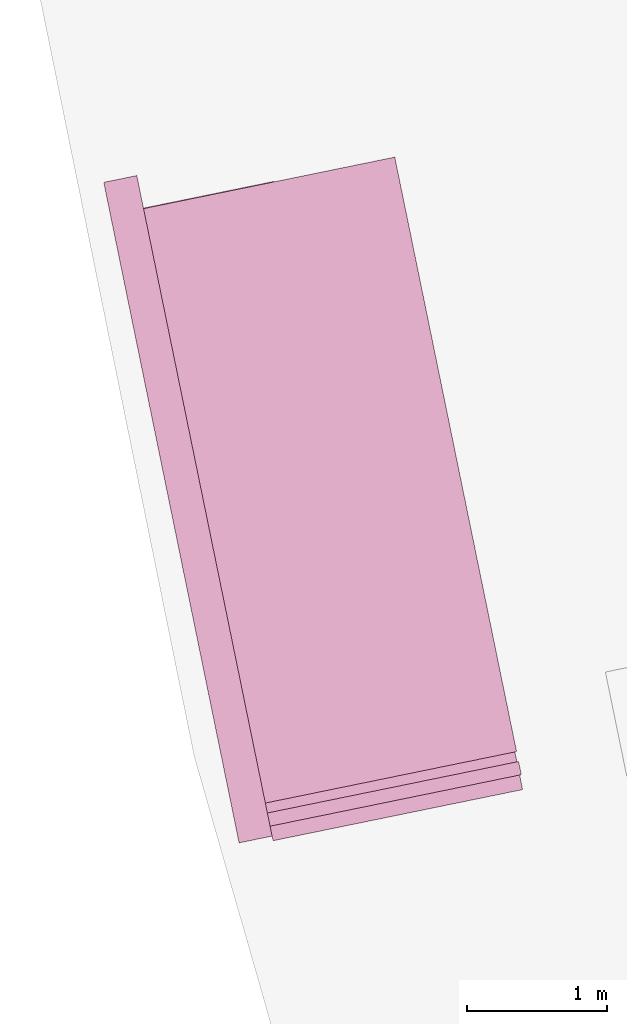
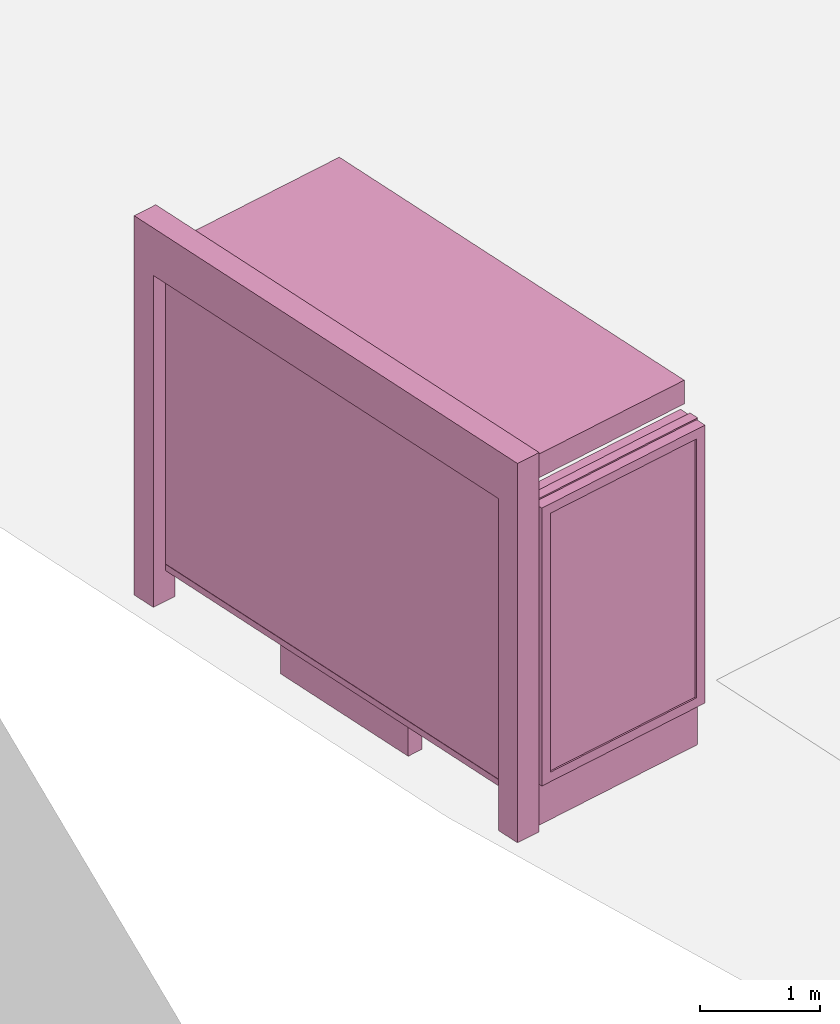
# One storey, part 26 of 200: 1 furnishing.
"""IFC4 building model written with IfcOpenShell, lengths in metres."""

from ifc_helpers import new_model, si_unit, origin_with_axes, place, context, subcontext, project, spatial, triangles, material, element, save


model = new_model("IFC4")

# Units and contexts
model_context = context("Model", 3, precision=1e-05, world=origin_with_axes())
body_context = subcontext(model_context, "Body", "Model", "MODEL_VIEW")
ifc_project = project(units=[si_unit("VOLUMEUNIT", "CUBIC_METRE"), si_unit("LENGTHUNIT", "METRE"), si_unit("AREAUNIT", "SQUARE_METRE")], contexts=[model_context])

# Site, building, storey
site_placement = place(None, origin_with_axes())
site = spatial("IfcSite", under=ifc_project, at=site_placement)
building_placement = place(site_placement, origin_with_axes())
building = spatial("IfcBuilding", under=site, at=building_placement, Name="Building")
storey_placement = place(building_placement, origin_with_axes())
storey = spatial("IfcBuildingStorey", under=building, at=storey_placement, Name="Ground")

# Furnishing
ifc_material = material(Name="busStop")
furnishing_placement = place(storey_placement, origin_with_axes())
element("IfcFurnishingElement", 1, at=furnishing_placement, inside=storey, material=ifc_material, Name="cw_instances_busStop_34", context=body_context, shape_type="Tessellation", body=[
    triangles([(176.34061056625512, -426.87686979367874, 3.3823837170154), (173.43771713825552, -423.0430857488788, 3.3823837170154), (174.30847300968287, -427.2932084161161, 3.3823837170154), (175.46985486398805, -422.62674691136294, 3.3823837170154), (176.34061066070228, -426.87686977432855, 3.623406387340317), (173.43771723270268, -423.0430857295286, 3.623406387340317), (175.4698549584352, -422.6267468920128, 3.623406387340317), (174.30847310413003, -427.293208396766, 3.623406387340317), (176.34061056625512, -426.87686979367874, 3.3823837170154), (175.4698549584352, -422.6267468920128, 3.623406387340317), (175.46985486398805, -422.62674691136294, 3.3823837170154), (176.34061066070228, -426.87686977432855, 3.623406387340317), (175.46985486398805, -422.62674691136294, 3.3823837170154), (173.43771723270268, -423.0430857295286, 3.623406387340317), (173.43771713825552, -423.0430857488788, 3.3823837170154), (175.4698549584352, -422.6267468920128, 3.623406387340317), (173.43771713825552, -423.0430857488788, 3.3823837170154), (174.30847310413003, -427.293208396766, 3.623406387340317), (174.30847300968287, -427.2932084161161, 3.3823837170154), (173.43771723270268, -423.0430857295286, 3.623406387340317), (174.30847300968287, -427.2932084161161, 3.3823837170154), (176.34061066070228, -426.87686977432855, 3.623406387340317), (176.34061056625512, -426.87686979367874, 3.3823837170154), (174.30847310413003, -427.293208396766, 3.623406387340317), (174.5445913562034, -427.2448329499997, 3.864428655961051), (174.35684887746848, -427.5293264015106, 3.864428655961051), (174.3084734661775, -427.2932083225904, 3.864428655961051), (174.59296676749437, -427.48095102891995, 3.864428655961051), (174.5445913562034, -427.2448329499997, 3.623406387340317), (174.59296676749437, -427.48095102891995, 3.864428655961051), (174.5445913562034, -427.2448329499997, 3.864428655961051), (174.59296676749437, -427.48095102891995, 3.623406387340317), (173.62546032004596, -422.75859236655236, 3.623406387340317), (173.38934224112572, -422.80696777784334, 3.864428655961051), (173.38934224112572, -422.80696777784334, 3.623406387340317), (173.62546032004596, -422.75859236655236, 3.864428655961051), (173.43771761049138, -423.04308565212807, 3.623406387340317), (173.38934224112572, -422.80696777784334, 3.864428655961051), (173.43771761049138, -423.04308565212807, 3.864428655961051), (173.38934224112572, -422.80696777784334, 3.623406387340317), (174.35684870431535, -427.5293264369859, 3.623406387340317), (174.59296676749437, -427.48095102891995, 3.864428655961051), (174.59296676749437, -427.48095102891995, 3.623406387340317), (174.35684887746848, -427.5293264015106, 3.864428655961051), (173.67383550051727, -422.99471027953734, 3.864428655961051), (173.43771761049138, -423.04308565212807, 3.864428655961051), (173.67383550051727, -422.99471027953734, 3.623406387340317), (173.67383550051727, -422.99471027953734, 3.864428655961051), (174.35684870431535, -427.5293264369859, 3.623406387340317), (174.3084734661775, -427.2932083225904, 3.864428655961051), (174.35684887746848, -427.5293264015106, 3.864428655961051), (174.3084734661775, -427.2932083225904, 3.623406387340317), (173.62546032004596, -422.75859236655236, 3.864428655961051), (173.38934224112572, -422.80696777784334, 3.864428655961051), (173.62546032004596, -422.75859236655236, 3.623406387340317), (173.62546032004596, -422.75859236655236, 3.864428655961051), (174.35684785429083, -427.52932661113726, 9.480218712634252e-07), (174.59296564986954, -427.4809512578967, 8.998173693347766e-07), (174.30847244299986, -427.293208532217, 9.480218712634252e-07), (174.35684785429083, -427.52932661113726, 9.480218712634252e-07), (174.3084734661775, -427.2932083225904, 3.623406387340317), (174.54459041173172, -427.24483314350124, 8.998173693347766e-07), (174.5445913562034, -427.2448329499997, 3.623406387340317), (174.30847244299986, -427.293208532217, 9.480218712634252e-07), (174.59296564986954, -427.4809512578967, 8.998173693347766e-07), (174.54459041173172, -427.24483314350124, 8.998173693347766e-07), (173.62545949305732, -422.7585940941677, 8.998173693347766e-07), (173.38934121794804, -422.80696798747, 9.480218712634252e-07), (173.673834865648, -422.9947119841936, 8.998173693347766e-07), (173.62545949305732, -422.7585940941677, 8.998173693347766e-07), (173.67383550051727, -422.99471027953734, 3.623406387340317), (173.43771689691613, -423.0430873729094, 9.480218712634252e-07), (173.43771761049138, -423.04308565212807, 3.623406387340317), (173.673834865648, -422.9947119841936, 8.998173693347766e-07), (173.38934121794804, -422.80696798747, 9.480218712634252e-07), (173.43771689691613, -423.0430873729094, 9.480218712634252e-07), (174.60586565573203, -422.8040135152526, 0.34596862720110877), (173.58096167477387, -423.0139938430587, 3.3823837170154), (173.58096082474935, -423.01399401721005, 0.34596880395094914), (174.6058664270506, -422.8040133572264, 3.3823837170154), (173.5841858467937, -423.0297351962361, 0.34596880395094914), (174.60909144909493, -422.81975453625245, 3.3823837170154), (174.6090906777764, -422.8197546942787, 0.34596862720110877), (173.58418669681822, -423.0297350220847, 3.3823837170154), (174.6090906777764, -422.8197546942787, 0.34596862720110877), (174.6058664270506, -422.8040133572264, 3.3823837170154), (174.60586565573203, -422.8040135152526, 0.34596862720110877), (174.60909144909493, -422.81975453625245, 3.3823837170154), (173.58499212246122, -423.03367058937505, 0.31383250146818464), (174.60505937154127, -422.8000783206831, 0.3138323086501769), (173.58015458778215, -423.01005881296544, 0.31383250146818464), (174.6098969062203, -422.8236900970927, 0.3138323086501769), (173.58499212246122, -423.03367058937505, 0.378105122501881), (174.60505938728247, -422.80007831745803, 0.3781049296838733), (174.6098969219615, -422.8236900938677, 0.3781049296838733), (173.58015458778215, -423.01005881296544, 0.378105122501881), (173.58499212246122, -423.03367058937505, 0.31383250146818464), (174.6098969219615, -422.8236900938677, 0.3781049296838733), (174.6098969062203, -422.8236900970927, 0.3138323086501769), (173.58499212246122, -423.03367058937505, 0.378105122501881), (174.60505937154127, -422.8000783206831, 0.3138323086501769), (173.58015458778215, -423.01005881296544, 0.378105122501881), (173.58015458778215, -423.01005881296544, 0.31383250146818464), (174.60505938728247, -422.80007831745803, 0.3781049296838733), (174.60505938728247, -422.80007831745803, 0.3781049296838733), (174.6098969062203, -422.8236900970927, 0.3138323086501769), (174.6098969219615, -422.8236900938677, 0.3781049296838733), (174.60505937154127, -422.8000783206831, 0.3138323086501769), (174.63082386660048, -422.81559415936135, 0.3781049296838733), (174.58413291365076, -422.8081759104721, 0.3781049296838733), (174.62748435293403, -422.79929415217987, 0.3781049296838733), (174.5874724273172, -422.8244759176535, 0.3781049296838733), (174.63082361474136, -422.8155942109617, 1.446135057859462e-07), (174.62748435293403, -422.79929415217987, 0.3781049296838733), (174.6274841010749, -422.7992942037803, 1.446135057859462e-07), (174.63082386660048, -422.81559415936135, 0.3781049296838733), (174.6274841010749, -422.7992942037803, 1.446135057859462e-07), (174.58413291365076, -422.8081759104721, 0.3781049296838733), (174.5841328034624, -422.8081759330472, 1.606816730954958e-07), (174.62748435293403, -422.79929415217987, 0.3781049296838733), (174.5841328034624, -422.8081759330472, 1.606816730954958e-07), (174.5874724273172, -422.8244759176535, 0.3781049296838733), (174.58747231712886, -422.8244759402287, 1.606816730954958e-07), (174.58413291365076, -422.8081759104721, 0.3781049296838733), (174.58747231712886, -422.8244759402287, 1.606816730954958e-07), (174.63082386660048, -422.81559415936135, 0.3781049296838733), (174.63082361474136, -422.8155942109617, 1.446135057859462e-07), (174.5874724273172, -422.8244759176535, 0.3781049296838733), (174.34685790137442, -425.9517340658489, 1.1247720651681516), (173.874052638298, -424.4084083204333, 1.1247721615771553), (174.0243558466721, -424.3776144923762, 1.1247720651681516), (174.19655488189463, -425.9825278552057, 1.1247721615771553), (174.02435565777776, -424.3776145310765, 4.98113186596037e-07), (174.34685790137442, -425.9517340658489, 0.9640904563453251), (174.0243558466721, -424.3776144923762, 0.9640904563453251), (174.34685757080933, -425.9517341335744, 4.98113186596037e-07), (173.8740522605093, -424.4084083978339, 5.302495212151362e-07), (174.0243558466721, -424.3776144923762, 0.9640904563453251), (173.874052638298, -424.4084083204333, 0.9640905527543289), (174.02435565777776, -424.3776145310765, 4.98113186596037e-07), (174.19655450410596, -425.98252793260633, 5.302495212151362e-07), (173.874052638298, -424.4084083204333, 0.9640905527543289), (174.19655488189463, -425.9825278552057, 0.9640905527543289), (173.8740522605093, -424.4084083978339, 5.302495212151362e-07), (174.34685757080933, -425.9517341335744, 4.98113186596037e-07), (174.19655488189463, -425.9825278552057, 0.9640905527543289), (174.34685790137442, -425.9517340658489, 0.9640904563453251), (174.19655450410596, -425.98252793260633, 5.302495212151362e-07), (174.65400357439609, -424.248613494501, 1.1247719687591475), (174.97650570780436, -425.82273305184856, 0.9640903599363211), (174.97650573928678, -425.82273304539854, 1.1247719687591475), (174.6540035586549, -424.24861349772607, 0.9640903599363211), (173.874052638298, -424.4084083204333, 1.1247721615771553), (174.0243558466721, -424.3776144923762, 1.1247720651681516), (174.19655488189463, -425.9825278552057, 1.1247721615771553), (173.874052638298, -424.4084083204333, 1.1247721615771553), (174.34685790137442, -425.9517340658489, 1.1247720651681516), (174.19655488189463, -425.9825278552057, 1.1247721615771553), (174.97650573928678, -425.82273304539854, 1.1247719687591475), (174.65400357439609, -424.248613494501, 1.1247719687591475), (174.97650570780436, -425.82273305184856, 0.9640903599363211), (174.97650573928678, -425.82273304539854, 1.1247719687591475), (174.65400357439609, -424.248613494501, 1.1247719687591475), (174.6540035586549, -424.24861349772607, 0.9640903599363211), (174.48756851526701, -427.3990797429234, 0.34596880395094914), (173.56459436062397, -422.89407683812993, 3.5028950521778586), (173.56459343189348, -422.89407702840646, 0.34596880395094914), (174.48756917639722, -427.39907960747234, 3.5028950521778586), (173.54885223712625, -422.89730205367584, 0.34596880395094914), (174.47182799737118, -427.4023046295167, 3.5028950521778586), (174.471827336241, -427.40230476496777, 0.34596880395094914), (173.54885318159793, -422.8973018601743, 3.5028950521778586), (174.6909800972454, -427.4790123437563, 0.5809565598614106), (176.2860976666566, -427.1522077685599, 3.219113622848009), (176.28609709997357, -427.1522078846608, 0.5809562706343991), (174.6909806954108, -427.4790122212054, 3.219113622848009), (174.5997579506864, -427.51410367439865, 0.48454753993594585), (176.28932212201792, -427.1679490636868, 0.5809562706343991), (176.38376950255147, -427.1486004268342, 0.48454721857259964), (174.69420511928973, -427.4947535227824, 0.5809565598614106), (176.28932268870093, -427.1679489475859, 3.219113622848009), (176.38377004619858, -427.1485987572693, 3.3155225302963025), (174.69420571745513, -427.4947534002314, 3.219113622848009), (174.5997585960754, -427.5141035421726, 3.3155225302963025), (174.69420511928973, -427.4947535227824, 0.5809565598614106), (176.28609709997357, -427.1522078846608, 0.5809562706343991), (176.28932212201792, -427.1679490636868, 0.5809562706343991), (174.6909800972454, -427.4790123437563, 0.5809565598614106), (176.28932212201792, -427.1679490636868, 0.5809562706343991), (176.2860976666566, -427.1522077685599, 3.219113622848009), (176.28932268870093, -427.1679489475859, 3.219113622848009), (176.28609709997357, -427.1522078846608, 0.5809562706343991), (176.28932268870093, -427.1679489475859, 3.219113622848009), (174.6909806954108, -427.4790122212054, 3.219113622848009), (174.69420571745513, -427.4947534002314, 3.219113622848009), (176.2860976666566, -427.1522077685599, 3.219113622848009), (174.69420571745513, -427.4947534002314, 3.219113622848009), (174.6909800972454, -427.4790123437563, 0.5809565598614106), (174.69420511928973, -427.4947535227824, 0.5809565598614106), (174.6909806954108, -427.4790122212054, 3.219113622848009), (176.32181022216824, -426.84617580664496, 3.3155225302963025), (174.5997585960754, -427.5141035421726, 3.3155225302963025), (174.53779905538656, -427.21168053349777, 3.3155225302963025), (176.38377004619858, -427.1485987572693, 3.3155225302963025), (176.32180937214372, -426.8461759807963, 0.48454721857259964), (176.38377004619858, -427.1485987572693, 3.3155225302963025), (176.32181022216824, -426.84617580664496, 3.3155225302963025), (176.38376950255147, -427.1486004268342, 0.48454721857259964), (174.5997579506864, -427.51410367439865, 0.48454753993594585), (174.53779905538656, -427.21168053349777, 3.3155225302963025), (174.5997585960754, -427.5141035421726, 3.3155225302963025), (174.5377982998092, -427.211680688299, 0.48454753993594585), (174.63547045897448, -427.20807172215876, 0.5809565598614106), (176.23058788671494, -426.88126717598755, 3.219113622848009), (174.63547124603423, -427.2080715609075, 3.219113622848009), (176.23058732003193, -426.88126729208847, 0.5809562706343991), (174.5377982998092, -427.211680688299, 0.48454753993594585), (176.22736229798755, -426.86552611306246, 0.5809562706343991), (174.63224543693013, -427.19233054313275, 0.5809565598614106), (176.32180937214372, -426.8461759807963, 0.48454721857259964), (176.22736286467057, -426.86552599696154, 3.219113622848009), (176.32181022216824, -426.84617580664496, 3.3155225302963025), (174.63224622398985, -427.1923303818815, 3.219113622848009), (174.53779905538656, -427.21168053349777, 3.3155225302963025), (174.63224543693013, -427.19233054313275, 0.5809565598614106), (176.23058732003193, -426.88126729208847, 0.5809562706343991), (174.63547045897448, -427.20807172215876, 0.5809565598614106), (176.22736229798755, -426.86552611306246, 0.5809562706343991), (176.22736229798755, -426.86552611306246, 0.5809562706343991), (176.23058788671494, -426.88126717598755, 3.219113622848009), (176.23058732003193, -426.88126729208847, 0.5809562706343991), (176.22736286467057, -426.86552599696154, 3.219113622848009), (176.22736286467057, -426.86552599696154, 3.219113622848009), (174.63547124603423, -427.2080715609075, 3.219113622848009), (176.23058788671494, -426.88126717598755, 3.219113622848009), (174.63224622398985, -427.1923303818815, 3.219113622848009), (174.63224622398985, -427.1923303818815, 3.219113622848009), (174.63547045897448, -427.20807172215876, 0.5809565598614106), (174.63547124603423, -427.2080715609075, 3.219113622848009), (174.63224543693013, -427.19233054313275, 0.5809565598614106), (176.374472992956, -427.04215068590906, 3.328512133158346), (174.55910361792715, -427.31566852978233, 3.328512133158346), (176.35512316706723, -426.9477051071664, 3.328512133158346), (174.5784537501933, -427.4101156039385, 3.328512133158346), (176.3744726769035, -427.04215250566796, 0.0), (176.35512316706723, -426.9477051071664, 3.328512133158346), (176.35512250593706, -426.9477052426175, 0.0), (176.374472992956, -427.04215068590906, 3.328512133158346), (176.35512250593706, -426.9477052426175, 0.0), (174.55910361792715, -427.31566852978233, 3.328512133158346), (174.55910287809098, -427.31566868135855, 5.141813539055866e-07), (176.35512316706723, -426.9477051071664, 3.328512133158346), (174.55910287809098, -427.31566868135855, 5.141813539055866e-07), (174.5784537501933, -427.4101156039385, 3.328512133158346), (174.57845301035712, -427.4101157555147, 5.141813539055866e-07), (174.55910361792715, -427.31566852978233, 3.328512133158346), (174.57845301035712, -427.4101157555147, 5.141813539055866e-07), (176.374472992956, -427.04215068590906, 3.328512133158346), (176.3744726769035, -427.04215250566796, 0.0), (174.5784537501933, -427.4101156039385, 3.328512133158346), (174.49150381395884, -427.39827348660606, 0.31383250146818464), (173.56488588401888, -422.99557618277385, 0.31383250146818464), (174.46789194310202, -427.4031110406353, 0.31383250146818464), (173.58849764468732, -422.9907386513198, 0.31383250146818464), (174.49150381395884, -427.39827348660606, 0.378105122501881), (173.56488588401888, -422.99557618277385, 0.378105122501881), (173.58849764468732, -422.9907386513198, 0.378105122501881), (174.46789194310202, -427.4031110406353, 0.378105122501881), (174.49150381395884, -427.39827348660606, 0.31383250146818464), (173.58849764468732, -422.9907386513198, 0.378105122501881), (173.58849764468732, -422.9907386513198, 0.31383250146818464), (174.49150381395884, -427.39827348660606, 0.378105122501881), (173.56488588401888, -422.99557618277385, 0.31383250146818464), (174.46789194310202, -427.4031110406353, 0.378105122501881), (174.46789194310202, -427.4031110406353, 0.31383250146818464), (173.56488588401888, -422.99557618277385, 0.378105122501881), (174.16519614520405, -425.82493276341637, 1.5289466322217304), (173.9071947815587, -424.5656370308466, 2.8143998402358568), (174.16519652299274, -425.82493268601576, 2.8143998402358568), (173.90719440377003, -424.5656371082472, 1.5289466322217304), (174.17197755733739, -425.7907395212252, 1.5610831275225028), (173.92687628547841, -424.5944086024317, 2.7822635377530918), (173.9268757345366, -424.5944087153076, 1.5610831275225028), (174.17197774623173, -425.7907394825249, 2.7822635377530918), (174.16519614520405, -425.82493276341637, 1.5289466322217304), (173.93616704869316, -424.5597012492873, 1.5289466322217304), (173.90719440377003, -424.5656371082472, 1.5289466322217304), (174.19416860123286, -425.8189969431568, 1.5289466322217304), (173.90719440377003, -424.5656371082472, 1.5289466322217304), (173.93616722184632, -424.55970121381205, 2.8143998402358568), (173.9071947815587, -424.5656370308466, 2.8143998402358568), (173.93616704869316, -424.5597012492873, 1.5289466322217304), (173.9071947815587, -424.5656370308466, 2.8143998402358568), (174.19416897902155, -425.81899686575616, 2.8143998402358568), (174.16519652299274, -425.82493268601576, 2.8143998402358568), (173.93616722184632, -424.55970121381205, 2.8143998402358568), (174.16519652299274, -425.82493268601576, 2.8143998402358568), (174.19416860123286, -425.8189969431568, 1.5289466322217304), (174.16519614520405, -425.82493276341637, 1.5289466322217304), (174.19416897902155, -425.81899686575616, 2.8143998402358568), (173.8318763863978, -424.1980134520256, 1.5289466322217304), (173.67062585915593, -423.41095346441625, 2.8143998402358568), (173.83187693373065, -424.1980132414775, 2.8143998402358568), (173.67062548136724, -423.41095354181687, 1.5289466322217304), (173.83865758061157, -424.163820106864, 1.5610831275225028), (173.69030707005905, -423.4397250468283, 2.7822635377530918), (173.69030678671754, -423.43972510487873, 1.5610831275225028), (173.8386581315534, -424.1638199939881, 2.7822635377530918), (173.8318763863978, -424.1980134520256, 1.5289466322217304), (173.69959792165486, -423.40501772478234, 1.5289466322217304), (173.67062548136724, -423.41095354181687, 1.5289466322217304), (173.86084903132095, -424.19207759306573, 1.5289466322217304), (173.67062548136724, -423.41095354181687, 1.5289466322217304), (173.69959829944352, -423.4050176473817, 2.8143998402358568), (173.67062585915593, -423.41095346441625, 2.8143998402358568), (173.69959792165486, -423.40501772478234, 1.5289466322217304), (173.67062585915593, -423.41095346441625, 2.8143998402358568), (173.86084937401827, -424.19207742444297, 2.8143998402358568), (173.83187693373065, -424.1980132414775, 2.8143998402358568), (173.69959829944352, -423.4050176473817, 2.8143998402358568), (173.83187693373065, -424.1980132414775, 2.8143998402358568), (173.86084903132095, -424.19207759306573, 1.5289466322217304), (173.8318763863978, -424.1980134520256, 1.5289466322217304), (173.86084937401827, -424.19207742444297, 2.8143998402358568), (174.19416860123286, -425.8189969431568, 1.5289466322217304), (173.9426170080098, -424.59118367391306, 1.5610831275225028), (173.93616704869316, -424.5597012492873, 1.5289466322217304), (174.18771854746907, -425.7875145378812, 1.5610831275225028), (173.9426172756101, -424.59118361908764, 2.7822635377530918), (173.93616722184632, -424.55970121381205, 2.8143998402358568), (174.18771892525774, -425.78751446048057, 2.7822635377530918), (174.19416897902155, -425.81899686575616, 2.8143998402358568), (173.86084903132095, -424.19207759306573, 1.5289466322217304), (173.70604796574358, -423.43650008283436, 1.5610831275225028), (173.69959792165486, -423.40501772478234, 1.5289466322217304), (173.85439894853192, -424.16059504611934, 1.5610831275225028), (173.70604834353225, -423.43650000543374, 2.7822635377530918), (173.69959829944352, -423.4050176473817, 2.8143998402358568), (173.8543993105794, -424.16059497194374, 2.7822635377530918), (173.86084937401827, -424.19207742444297, 2.8143998402358568), (174.18771854746907, -425.7875145378812, 1.5610831275225028), (173.9268757345366, -424.5944087153076, 1.5610831275225028), (173.9426170080098, -424.59118367391306, 1.5610831275225028), (174.17197755733739, -425.7907395212252, 1.5610831275225028), (173.9426170080098, -424.59118367391306, 1.5610831275225028), (173.92687628547841, -424.5944086024317, 2.7822635377530918), (173.9426172756101, -424.59118361908764, 2.7822635377530918), (173.9268757345366, -424.5944087153076, 1.5610831275225028), (173.9426172756101, -424.59118361908764, 2.7822635377530918), (174.17197774623173, -425.7907394825249, 2.7822635377530918), (174.18771892525774, -425.78751446048057, 2.7822635377530918), (173.92687628547841, -424.5944086024317, 2.7822635377530918), (174.18771892525774, -425.78751446048057, 2.7822635377530918), (174.17197755733739, -425.7907395212252, 1.5610831275225028), (174.18771854746907, -425.7875145378812, 1.5610831275225028), (174.17197774623173, -425.7907394825249, 2.7822635377530918), (173.85439894853192, -424.16059504611934, 1.5610831275225028), (173.69030678671754, -423.43972510487873, 1.5610831275225028), (173.70604796574358, -423.43650008283436, 1.5610831275225028), (173.83865758061157, -424.163820106864, 1.5610831275225028), (173.70604796574358, -423.43650008283436, 1.5610831275225028), (173.69030707005905, -423.4397250468283, 2.7822635377530918), (173.70604834353225, -423.43650000543374, 2.7822635377530918), (173.69030678671754, -423.43972510487873, 1.5610831275225028), (173.70604834353225, -423.43650000543374, 2.7822635377530918), (173.8386581315534, -424.1638199939881, 2.7822635377530918), (173.8543993105794, -424.16059497194374, 2.7822635377530918), (173.69030707005905, -423.4397250468283, 2.7822635377530918), (173.8543993105794, -424.16059497194374, 2.7822635377530918), (173.83865758061157, -424.163820106864, 1.5610831275225028), (173.85439894853192, -424.16059504611934, 1.5610831275225028), (173.8386581315534, -424.1638199939881, 2.7822635377530918)], [[1, 3, 2], [2, 4, 1], [5, 7, 6], [6, 8, 5], [9, 11, 10], [10, 12, 9], [13, 15, 14], [14, 16, 13], [17, 19, 18], [18, 20, 17], [21, 23, 22], [22, 24, 21], [25, 27, 26], [26, 28, 25], [29, 31, 30], [30, 32, 29], [33, 35, 34], [34, 36, 33], [37, 39, 38], [38, 40, 37], [41, 43, 42], [42, 44, 41], [45, 46, 27], [27, 25, 45], [47, 48, 31], [31, 29, 47], [49, 51, 50], [50, 52, 49], [52, 50, 39], [39, 37, 52], [53, 54, 46], [46, 45, 53], [55, 56, 48], [48, 47, 55], [43, 41, 57], [57, 58, 43], [49, 52, 59], [59, 60, 49], [61, 63, 62], [62, 64, 61], [29, 32, 65], [65, 66, 29], [35, 33, 67], [67, 68, 35], [55, 47, 69], [69, 70, 55], [71, 73, 72], [72, 74, 71], [37, 40, 75], [75, 76, 37], [77, 79, 78], [78, 80, 77], [81, 83, 82], [82, 84, 81], [85, 87, 86], [86, 88, 85], [89, 91, 90], [90, 92, 89], [93, 95, 94], [94, 96, 93], [97, 99, 98], [98, 100, 97], [101, 103, 102], [102, 104, 101], [105, 107, 106], [106, 108, 105], [109, 111, 110], [110, 112, 109], [113, 115, 114], [114, 116, 113], [117, 119, 118], [118, 120, 117], [121, 123, 122], [122, 124, 121], [125, 127, 126], [126, 128, 125], [129, 131, 130], [130, 132, 129], [133, 135, 134], [134, 136, 133], [137, 139, 138], [138, 140, 137], [141, 143, 142], [142, 144, 141], [145, 147, 146], [146, 148, 145], [149, 151, 150], [150, 152, 149], [153, 154, 138], [138, 139, 153], [155, 156, 142], [142, 143, 155], [157, 158, 146], [146, 147, 157], [131, 129, 159], [159, 160, 131], [157, 147, 161], [161, 162, 157], [138, 154, 163], [163, 164, 138], [165, 167, 166], [166, 168, 165], [169, 171, 170], [170, 172, 169], [173, 175, 174], [174, 176, 173], [177, 179, 178], [178, 180, 177], [179, 182, 181], [181, 178, 179], [182, 184, 183], [183, 181, 182], [184, 177, 180], [180, 183, 184], [185, 187, 186], [186, 188, 185], [189, 191, 190], [190, 192, 189], [193, 195, 194], [194, 196, 193], [197, 199, 198], [198, 200, 197], [201, 203, 202], [202, 204, 201], [205, 207, 206], [206, 208, 205], [209, 211, 210], [210, 212, 209], [213, 215, 214], [214, 216, 213], [217, 219, 218], [218, 220, 217], [220, 218, 221], [221, 222, 220], [222, 221, 223], [223, 224, 222], [224, 223, 219], [219, 217, 224], [225, 227, 226], [226, 228, 225], [229, 231, 230], [230, 232, 229], [233, 235, 234], [234, 236, 233], [237, 239, 238], [238, 240, 237], [241, 243, 242], [242, 244, 241], [245, 247, 246], [246, 248, 245], [249, 251, 250], [250, 252, 249], [253, 255, 254], [254, 256, 253], [257, 259, 258], [258, 260, 257], [261, 263, 262], [262, 264, 261], [265, 267, 266], [266, 268, 265], [269, 271, 270], [270, 272, 269], [273, 275, 274], [274, 276, 273], [277, 279, 278], [278, 280, 277], [281, 283, 282], [282, 284, 281], [285, 287, 286], [286, 288, 285], [289, 291, 290], [290, 292, 289], [293, 295, 294], [294, 296, 293], [297, 299, 298], [298, 300, 297], [301, 303, 302], [302, 304, 301], [305, 307, 306], [306, 308, 305], [309, 311, 310], [310, 312, 309], [313, 315, 314], [314, 316, 313], [317, 319, 318], [318, 320, 317], [321, 323, 322], [322, 324, 321], [325, 327, 326], [326, 328, 325], [327, 330, 329], [329, 326, 327], [330, 332, 331], [331, 329, 330], [332, 325, 328], [328, 331, 332], [333, 335, 334], [334, 336, 333], [335, 338, 337], [337, 334, 335], [338, 340, 339], [339, 337, 338], [340, 333, 336], [336, 339, 340], [341, 343, 342], [342, 344, 341], [345, 347, 346], [346, 348, 345], [349, 351, 350], [350, 352, 349], [353, 355, 354], [354, 356, 353], [357, 359, 358], [358, 360, 357], [361, 363, 362], [362, 364, 361], [365, 367, 366], [366, 368, 365], [369, 371, 370], [370, 372, 369]], closed=True),
])

save(model, "model.ifc")
